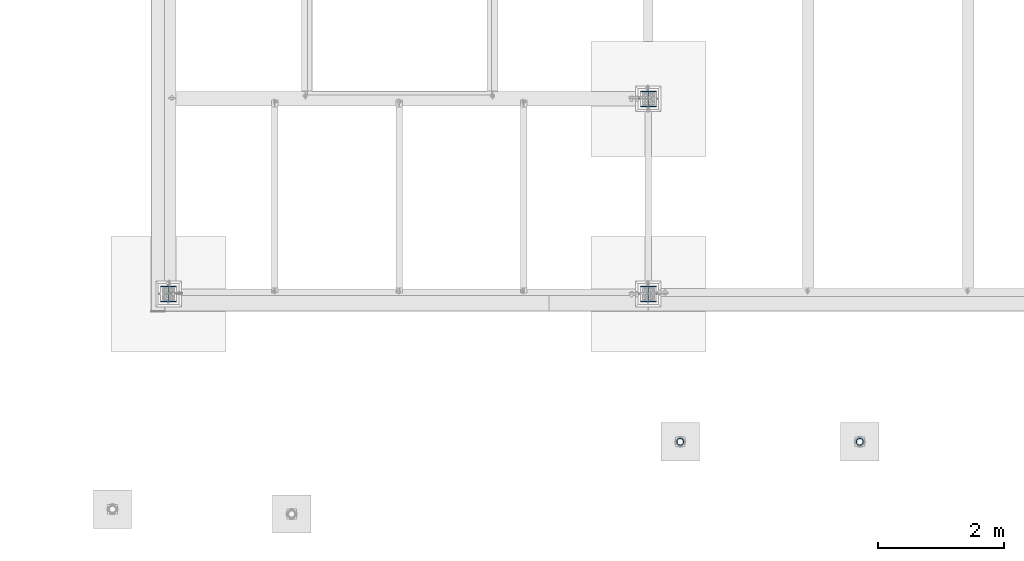
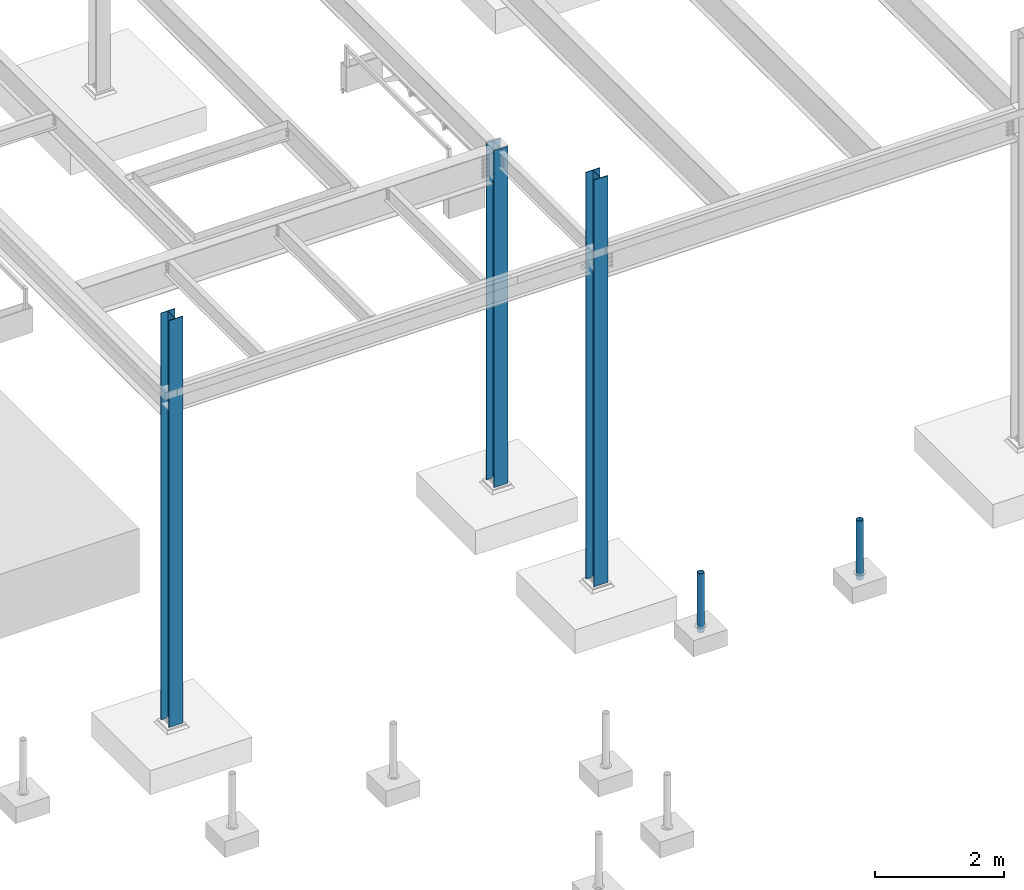
# One storey, part 1344 of 3843: 5 columns, 5 elements without a shape of their own.
"""IFC2X3 building model written with IfcOpenShell, lengths in millimetres."""

from ifc_helpers import new_model, si_unit, frame, origin_with_axes, place, context, subcontext, project, spatial, faceted_brep, material, type_object, element, aggregate, save


model = new_model("IFC2X3")

# Units and contexts
model_context = context("Model", 3, precision=1e-05, world=origin_with_axes())
body_context = subcontext(model_context, "Body", "Model", "MODEL_VIEW")
ifc_project = project(units=[si_unit("LENGTHUNIT", "METRE", prefix="MILLI"), si_unit("AREAUNIT", "SQUARE_METRE"), si_unit("VOLUMEUNIT", "CUBIC_METRE"), si_unit("MASSUNIT", "GRAM", prefix="KILO"), si_unit("TIMEUNIT", "SECOND"), si_unit("PLANEANGLEUNIT", "RADIAN"), si_unit("SOLIDANGLEUNIT", "STERADIAN"), si_unit("THERMODYNAMICTEMPERATUREUNIT", "DEGREE_CELSIUS"), si_unit("LUMINOUSINTENSITYUNIT", "LUMEN")], contexts=[model_context])

# Site, building, storey
site_placement = place(None, origin_with_axes())
site = spatial("IfcSite", under=ifc_project, at=site_placement, CompositionType="ELEMENT")
building_placement = place(site_placement, origin_with_axes())
building = spatial("IfcBuilding", under=site, at=building_placement, Name="Undefined", CompositionType="ELEMENT")
storey_placement = place(building_placement, origin_with_axes())
storey = spatial("IfcBuildingStorey", under=building, at=storey_placement, Name="Undefined", CompositionType="ELEMENT", Elevation=0.0)

# Assembly, column
assembly_1_placement = place(storey_placement, origin_with_axes())
assembly_1 = element("IfcElementAssembly", 1, at=assembly_1_placement, inside=storey, Name="PIPE_BOLLARD", AssemblyPlace="NOTDEFINED", PredefinedType="RIGID_FRAME")
ifc_material_1 = material()
column_type_1 = type_object("IfcColumnType", Name="PIPE4SCH40", PredefinedType="NOTDEFINED")
column_1_placement = place(assembly_1_placement, frame((10979.3882215321, 86768.0514528751, 30378.4), z_axis=(-1.0, 0.0, 0.0), x_axis=(0.0, 0.0, 1.0)))
column_1 = element("IfcColumn", 2, at=column_1_placement, type_object=column_type_1, material=ifc_material_1, Name="PIPE_BOLLARD", ObjectType="PIPE4SCH40", context=body_context, shape_type="Brep", body=[
    faceted_brep([(0.0, -51.1301999999996, 0.0), (0.0, -48.6277098894743, 15.8001007257844), (1117.6, -48.6277098894743, 15.8001007257844), (1117.6, -51.1301999999996, 0.0), (0.0, -41.3652007257897, 30.0535775067692), (1117.6, -41.3652007257897, 30.0535775067692), (0.0, -30.0535775067647, 41.3652007257915), (1117.6, -30.0535775067647, 41.3652007257915), (0.0, -15.8001007257899, 48.6277098894789), (1117.6, -15.8001007257899, 48.6277098894789), (0.0, 0.0, 51.1301999999996), (1117.6, 0.0, 51.1301999999996), (0.0, 15.8001007257899, 48.6277098894789), (1117.6, 15.8001007257899, 48.6277098894789), (0.0, 30.0535775067647, 41.3652007257915), (1117.6, 30.0535775067647, 41.3652007257915), (0.0, 41.3652007257897, 30.0535775067692), (1117.6, 41.3652007257897, 30.0535775067692), (0.0, 48.6277098894743, 15.8001007257844), (1117.6, 48.6277098894743, 15.8001007257844), (0.0, 51.1301999999996, 0.0), (1117.6, 51.1301999999996, 0.0), (0.0, 48.6277098894743, -15.8001007257844), (1117.6, 48.6277098894743, -15.8001007257844), (0.0, 41.3652007257897, -30.0535775067692), (1117.6, 41.3652007257897, -30.0535775067692), (0.0, 30.0535775067647, -41.3652007257915), (1117.6, 30.0535775067647, -41.3652007257915), (0.0, 15.8001007257899, -48.6277098894789), (1117.6, 15.8001007257899, -48.6277098894789), (0.0, 0.0, -51.1301999999996), (1117.6, 0.0, -51.1301999999996), (0.0, -15.8001007257899, -48.6277098894789), (1117.6, -15.8001007257899, -48.6277098894789), (0.0, -30.0535775067647, -41.3652007257915), (1117.6, -30.0535775067647, -41.3652007257915), (0.0, -41.3652007257897, -30.0535775067692), (1117.6, -41.3652007257897, -30.0535775067692), (0.0, -48.6277098894743, -15.8001007257844), (1117.6, -48.6277098894743, -15.8001007257844), (0.0, -57.1499999999996, 0.0), (0.0, -54.3528799062678, -17.6603212285263), (1117.6, -54.3528799062678, -17.6603212285263), (1117.6, -57.1499999999996, 0.0), (0.0, -46.2353212285279, -33.5919271685125), (1117.6, -46.2353212285279, -33.5919271685125), (0.0, -33.5919271685152, -46.2353212285234), (1117.6, -33.5919271685152, -46.2353212285234), (0.0, -17.6603212285281, -54.3528799062624), (1117.6, -17.6603212285281, -54.3528799062624), (0.0, 0.0, -57.1499999999942), (1117.6, 0.0, -57.1499999999942), (0.0, 17.6603212285281, -54.3528799062624), (1117.6, 17.6603212285281, -54.3528799062624), (0.0, 33.5919271685152, -46.2353212285234), (1117.6, 33.5919271685152, -46.2353212285234), (0.0, 46.2353212285279, -33.5919271685125), (1117.6, 46.2353212285279, -33.5919271685125), (0.0, 54.3528799062678, -17.6603212285263), (1117.6, 54.3528799062678, -17.6603212285263), (0.0, 57.1499999999996, 0.0), (1117.6, 57.1499999999996, 0.0), (0.0, 54.3528799062678, 17.6603212285263), (1117.6, 54.3528799062678, 17.6603212285263), (0.0, 46.2353212285279, 33.5919271685125), (1117.6, 46.2353212285279, 33.5919271685125), (0.0, 33.5919271685152, 46.2353212285234), (1117.6, 33.5919271685152, 46.2353212285234), (0.0, 17.6603212285281, 54.3528799062624), (1117.6, 17.6603212285281, 54.3528799062624), (0.0, 0.0, 57.1499999999942), (1117.6, 0.0, 57.1499999999942), (0.0, -17.6603212285281, 54.3528799062624), (1117.6, -17.6603212285281, 54.3528799062624), (0.0, -33.5919271685152, 46.2353212285234), (1117.6, -33.5919271685152, 46.2353212285234), (0.0, -46.2353212285279, 33.5919271685125), (1117.6, -46.2353212285279, 33.5919271685125), (0.0, -54.3528799062678, 17.6603212285263), (1117.6, -54.3528799062678, 17.6603212285263)], [[[0, 1, 2, 3]], [[1, 4, 5, 2]], [[4, 6, 7, 5]], [[6, 8, 9, 7]], [[8, 10, 11, 9]], [[10, 12, 13, 11]], [[12, 14, 15, 13]], [[14, 16, 17, 15]], [[16, 18, 19, 17]], [[18, 20, 21, 19]], [[20, 22, 23, 21]], [[22, 24, 25, 23]], [[24, 26, 27, 25]], [[26, 28, 29, 27]], [[28, 30, 31, 29]], [[30, 32, 33, 31]], [[32, 34, 35, 33]], [[34, 36, 37, 35]], [[36, 38, 39, 37]], [[38, 0, 3, 39]], [[40, 41, 42, 43]], [[41, 44, 45, 42]], [[44, 46, 47, 45]], [[46, 48, 49, 47]], [[48, 50, 51, 49]], [[50, 52, 53, 51]], [[52, 54, 55, 53]], [[54, 56, 57, 55]], [[56, 58, 59, 57]], [[58, 60, 61, 59]], [[60, 62, 63, 61]], [[62, 64, 65, 63]], [[64, 66, 67, 65]], [[66, 68, 69, 67]], [[68, 70, 71, 69]], [[70, 72, 73, 71]], [[72, 74, 75, 73]], [[74, 76, 77, 75]], [[76, 78, 79, 77]], [[78, 40, 43, 79]], [[45, 47, 49, 51, 53, 55, 57, 59, 61, 63, 65, 67, 69, 71, 73, 75, 77, 79, 43, 42], [5, 7, 9, 11, 13, 15, 17, 19, 21, 23, 25, 27, 29, 31, 33, 35, 37, 39, 3, 2]], [[78, 76, 74, 72, 70, 68, 66, 64, 62, 60, 58, 56, 54, 52, 50, 48, 46, 44, 41, 40], [38, 36, 34, 32, 30, 28, 26, 24, 22, 20, 18, 16, 14, 12, 10, 8, 6, 4, 1, 0]]]),
])
aggregate(assembly_1, [column_1])

assembly_2_placement = place(storey_placement, origin_with_axes())
assembly_2 = element("IfcElementAssembly", 3, at=assembly_2_placement, inside=storey, Name="PIPE_BOLLARD", AssemblyPlace="NOTDEFINED", PredefinedType="RIGID_FRAME")
column_2_placement = place(assembly_2_placement, frame((8126.610938, 86767.987501, 30378.4), z_axis=(-1.0, 0.0, 0.0), x_axis=(0.0, 0.0, 1.0)))
column_2 = element("IfcColumn", 4, at=column_2_placement, type_object=column_type_1, material=ifc_material_1, Name="PIPE_BOLLARD", ObjectType="PIPE4SCH40", context=body_context, shape_type="Brep", body=[
    faceted_brep([(0.0, -51.1301999999996, 0.0), (0.0, -48.6277098894743, 15.8001007257844), (1117.6, -48.6277098894743, 15.8001007257844), (1117.6, -51.1301999999996, 0.0), (0.0, -41.3652007257897, 30.0535775067692), (1117.6, -41.3652007257897, 30.0535775067692), (0.0, -30.0535775067647, 41.3652007257915), (1117.6, -30.0535775067647, 41.3652007257915), (0.0, -15.8001007257899, 48.6277098894789), (1117.6, -15.8001007257899, 48.6277098894789), (0.0, 0.0, 51.1301999999996), (1117.6, 0.0, 51.1301999999996), (0.0, 15.8001007257899, 48.6277098894789), (1117.6, 15.8001007257899, 48.6277098894789), (0.0, 30.0535775067647, 41.3652007257915), (1117.6, 30.0535775067647, 41.3652007257915), (0.0, 41.3652007257897, 30.0535775067692), (1117.6, 41.3652007257897, 30.0535775067692), (0.0, 48.6277098894743, 15.8001007257844), (1117.6, 48.6277098894743, 15.8001007257844), (0.0, 51.1301999999996, 0.0), (1117.6, 51.1301999999996, 0.0), (0.0, 48.6277098894743, -15.8001007257844), (1117.6, 48.6277098894743, -15.8001007257844), (0.0, 41.3652007257897, -30.0535775067692), (1117.6, 41.3652007257897, -30.0535775067692), (0.0, 30.0535775067647, -41.3652007257915), (1117.6, 30.0535775067647, -41.3652007257915), (0.0, 15.8001007257899, -48.6277098894789), (1117.6, 15.8001007257899, -48.6277098894789), (0.0, 0.0, -51.1301999999996), (1117.6, 0.0, -51.1301999999996), (0.0, -15.8001007257899, -48.6277098894789), (1117.6, -15.8001007257899, -48.6277098894789), (0.0, -30.0535775067647, -41.3652007257915), (1117.6, -30.0535775067647, -41.3652007257915), (0.0, -41.3652007257897, -30.0535775067692), (1117.6, -41.3652007257897, -30.0535775067692), (0.0, -48.6277098894743, -15.8001007257844), (1117.6, -48.6277098894743, -15.8001007257844), (0.0, -57.1499999999996, 0.0), (0.0, -54.3528799062678, -17.6603212285263), (1117.6, -54.3528799062678, -17.6603212285263), (1117.6, -57.1499999999996, 0.0), (0.0, -46.2353212285279, -33.5919271685125), (1117.6, -46.2353212285279, -33.5919271685125), (0.0, -33.5919271685152, -46.2353212285234), (1117.6, -33.5919271685152, -46.2353212285234), (0.0, -17.6603212285281, -54.3528799062624), (1117.6, -17.6603212285281, -54.3528799062624), (0.0, 0.0, -57.1499999999942), (1117.6, 0.0, -57.1499999999942), (0.0, 17.6603212285281, -54.3528799062624), (1117.6, 17.6603212285281, -54.3528799062624), (0.0, 33.5919271685152, -46.2353212285234), (1117.6, 33.5919271685152, -46.2353212285234), (0.0, 46.2353212285279, -33.5919271685125), (1117.6, 46.2353212285279, -33.5919271685125), (0.0, 54.3528799062678, -17.6603212285263), (1117.6, 54.3528799062678, -17.6603212285263), (0.0, 57.1499999999996, 0.0), (1117.6, 57.1499999999996, 0.0), (0.0, 54.3528799062678, 17.6603212285263), (1117.6, 54.3528799062678, 17.6603212285263), (0.0, 46.2353212285279, 33.5919271685125), (1117.6, 46.2353212285279, 33.5919271685125), (0.0, 33.5919271685152, 46.2353212285234), (1117.6, 33.5919271685152, 46.2353212285234), (0.0, 17.6603212285281, 54.3528799062624), (1117.6, 17.6603212285281, 54.3528799062624), (0.0, 0.0, 57.1499999999942), (1117.6, 0.0, 57.1499999999942), (0.0, -17.6603212285281, 54.3528799062624), (1117.6, -17.6603212285281, 54.3528799062624), (0.0, -33.5919271685152, 46.2353212285234), (1117.6, -33.5919271685152, 46.2353212285234), (0.0, -46.2353212285279, 33.5919271685125), (1117.6, -46.2353212285279, 33.5919271685125), (0.0, -54.3528799062678, 17.6603212285263), (1117.6, -54.3528799062678, 17.6603212285263)], [[[0, 1, 2, 3]], [[1, 4, 5, 2]], [[4, 6, 7, 5]], [[6, 8, 9, 7]], [[8, 10, 11, 9]], [[10, 12, 13, 11]], [[12, 14, 15, 13]], [[14, 16, 17, 15]], [[16, 18, 19, 17]], [[18, 20, 21, 19]], [[20, 22, 23, 21]], [[22, 24, 25, 23]], [[24, 26, 27, 25]], [[26, 28, 29, 27]], [[28, 30, 31, 29]], [[30, 32, 33, 31]], [[32, 34, 35, 33]], [[34, 36, 37, 35]], [[36, 38, 39, 37]], [[38, 0, 3, 39]], [[40, 41, 42, 43]], [[41, 44, 45, 42]], [[44, 46, 47, 45]], [[46, 48, 49, 47]], [[48, 50, 51, 49]], [[50, 52, 53, 51]], [[52, 54, 55, 53]], [[54, 56, 57, 55]], [[56, 58, 59, 57]], [[58, 60, 61, 59]], [[60, 62, 63, 61]], [[62, 64, 65, 63]], [[64, 66, 67, 65]], [[66, 68, 69, 67]], [[68, 70, 71, 69]], [[70, 72, 73, 71]], [[72, 74, 75, 73]], [[74, 76, 77, 75]], [[76, 78, 79, 77]], [[78, 40, 43, 79]], [[45, 47, 49, 51, 53, 55, 57, 59, 61, 63, 65, 67, 69, 71, 73, 75, 77, 79, 43, 42], [5, 7, 9, 11, 13, 15, 17, 19, 21, 23, 25, 27, 29, 31, 33, 35, 37, 39, 3, 2]], [[78, 76, 74, 72, 70, 68, 66, 64, 62, 60, 58, 56, 54, 52, 50, 48, 46, 44, 41, 40], [38, 36, 34, 32, 30, 28, 26, 24, 22, 20, 18, 16, 14, 12, 10, 8, 6, 4, 1, 0]]]),
])
aggregate(assembly_2, [column_2])

assembly_3_placement = place(storey_placement, origin_with_axes())
assembly_3 = element("IfcElementAssembly", 5, at=assembly_3_placement, inside=storey, Name="COLUMN", AssemblyPlace="NOTDEFINED", PredefinedType="RIGID_FRAME")
ifc_material_2 = material(Name="STEEL/A992")
column_type_2 = type_object("IfcColumnType", Name="W10X49", PredefinedType="NOTDEFINED")
column_3_placement = place(assembly_3_placement, frame((0.0, 89115.9, 30022.8), z_axis=(0.0, 1.0, 0.0), x_axis=(0.0, 0.0, 1.0)))
column_3 = element("IfcColumn", 6, at=column_3_placement, type_object=column_type_2, material=ifc_material_2, Name="COLUMN", ObjectType="W10X49", context=body_context, shape_type="Brep", body=[
    faceted_brep([(63.4999999999964, 127.0, -127.0), (63.4999999999964, 127.0, -112.712499999994), (7772.4, 127.0, -112.712499999994), (7772.4, 127.0, -127.0), (63.4999999999964, 3.96875, -112.7125), (7772.4, 3.96875, -112.712499999994), (63.4999999999964, 3.96875, 112.7125), (7772.4, 3.96875, 112.712499999994), (63.4999999999964, 127.0, 112.712499999994), (7772.4, 127.0, 112.712499999994), (63.4999999999964, 127.0, 127.0), (7772.4, 127.0, 127.0), (63.4999999999964, -127.0, 127.0), (7772.4, -127.0, 127.0), (63.4999999999964, -127.0, 112.712499999994), (7772.4, -127.0, 112.712499999994), (63.4999999999964, -3.96875, 112.7125), (7772.4, -3.96875, 112.712499999994), (63.4999999999964, -3.96875, -112.7125), (7772.4, -3.96875, -112.712499999994), (63.4999999999964, -127.0, -112.712499999994), (7772.4, -127.0, -112.712499999994), (63.4999999999964, -127.0, -127.0), (7772.4, -127.0, -127.0)], [[[0, 1, 2, 3]], [[1, 4, 5, 2]], [[4, 6, 7, 5]], [[6, 8, 9, 7]], [[8, 10, 11, 9]], [[10, 12, 13, 11]], [[12, 14, 15, 13]], [[14, 16, 17, 15]], [[16, 18, 19, 17]], [[18, 20, 21, 19]], [[20, 22, 23, 21]], [[22, 0, 3, 23]], [[5, 7, 9, 11, 13, 15, 17, 19, 21, 23, 3, 2]], [[22, 20, 18, 16, 14, 12, 10, 8, 6, 4, 1, 0]]]),
])
aggregate(assembly_3, [column_3])

assembly_4_placement = place(storey_placement, origin_with_axes())
assembly_4 = element("IfcElementAssembly", 7, at=assembly_4_placement, inside=storey, Name="COLUMN", AssemblyPlace="NOTDEFINED", PredefinedType="RIGID_FRAME")
column_4_placement = place(assembly_4_placement, frame((7620.0, 89115.9, 30022.8), z_axis=(0.0, 1.0, 0.0), x_axis=(0.0, 0.0, 1.0)))
column_4 = element("IfcColumn", 8, at=column_4_placement, type_object=column_type_2, material=ifc_material_2, Name="COLUMN", ObjectType="W10X49", context=body_context, shape_type="Brep", body=[
    faceted_brep([(63.4999999999964, 127.0, -127.0), (63.4999999999964, 127.0, -112.712499999994), (7772.4, 127.0, -112.712499999994), (7772.4, 127.0, -127.0), (63.4999999999964, 3.96875, -112.7125), (7772.4, 3.96875, -112.712499999994), (63.4999999999964, 3.96875, 112.7125), (7772.4, 3.96875, 112.712499999994), (63.4999999999964, 127.0, 112.712499999994), (7772.4, 127.0, 112.712499999994), (63.4999999999964, 127.0, 127.0), (7772.4, 127.0, 127.0), (63.4999999999964, -127.0, 127.0), (7772.4, -127.0, 127.0), (63.4999999999964, -127.0, 112.712499999994), (7772.4, -127.0, 112.712499999994), (63.4999999999964, -3.96875, 112.7125), (7772.4, -3.96875, 112.712499999994), (63.4999999999964, -3.96875, -112.7125), (7772.4, -3.96875, -112.712499999994), (63.4999999999964, -127.0, -112.712499999994), (7772.4, -127.0, -112.712499999994), (63.4999999999964, -127.0, -127.0), (7772.4, -127.0, -127.0)], [[[0, 1, 2, 3]], [[1, 4, 5, 2]], [[4, 6, 7, 5]], [[6, 8, 9, 7]], [[8, 10, 11, 9]], [[10, 12, 13, 11]], [[12, 14, 15, 13]], [[14, 16, 17, 15]], [[16, 18, 19, 17]], [[18, 20, 21, 19]], [[20, 22, 23, 21]], [[22, 0, 3, 23]], [[5, 7, 9, 11, 13, 15, 17, 19, 21, 23, 3, 2]], [[22, 20, 18, 16, 14, 12, 10, 8, 6, 4, 1, 0]]]),
])
aggregate(assembly_4, [column_4])

assembly_5_placement = place(storey_placement, origin_with_axes())
assembly_5 = element("IfcElementAssembly", 9, at=assembly_5_placement, inside=storey, Name="COLUMN", AssemblyPlace="NOTDEFINED", PredefinedType="RIGID_FRAME")
column_5_placement = place(assembly_5_placement, frame((7620.0, 92214.7, 30022.8), z_axis=(0.0, 1.0, 0.0), x_axis=(0.0, 0.0, 1.0)))
column_5 = element("IfcColumn", 10, at=column_5_placement, type_object=column_type_2, material=ifc_material_2, Name="COLUMN", ObjectType="W10X49", context=body_context, shape_type="Brep", body=[
    faceted_brep([(63.4999999999964, 127.0, -127.0), (63.4999999999964, 127.0, -112.712499999994), (6451.60000000002, 127.0, -112.712499999994), (6451.60000000002, 127.0, -127.0), (63.4999999999964, 3.96875, -112.7125), (6451.60000000002, 3.96875, -112.712499999994), (63.4999999999964, 3.96875, 112.7125), (6451.60000000002, 3.96875, 112.712499999994), (63.4999999999964, 127.0, 112.712499999994), (6451.60000000002, 127.0, 112.712499999994), (63.4999999999964, 127.0, 127.0), (6451.60000000002, 127.0, 127.0), (63.4999999999964, -127.0, 127.0), (6451.60000000002, -127.0, 127.0), (63.4999999999964, -127.0, 112.712499999994), (6451.60000000002, -127.0, 112.712499999994), (63.4999999999964, -3.96875, 112.7125), (6451.60000000002, -3.96875, 112.712499999994), (63.4999999999964, -3.96875, -112.7125), (6451.60000000002, -3.96875, -112.712499999994), (63.4999999999964, -127.0, -112.712499999994), (6451.60000000002, -127.0, -112.712499999994), (63.4999999999964, -127.0, -127.0), (6451.60000000002, -127.0, -127.0)], [[[0, 1, 2, 3]], [[1, 4, 5, 2]], [[4, 6, 7, 5]], [[6, 8, 9, 7]], [[8, 10, 11, 9]], [[10, 12, 13, 11]], [[12, 14, 15, 13]], [[14, 16, 17, 15]], [[16, 18, 19, 17]], [[18, 20, 21, 19]], [[20, 22, 23, 21]], [[22, 0, 3, 23]], [[5, 7, 9, 11, 13, 15, 17, 19, 21, 23, 3, 2]], [[22, 20, 18, 16, 14, 12, 10, 8, 6, 4, 1, 0]]]),
])
aggregate(assembly_5, [column_5])

save(model, "model.ifc")
